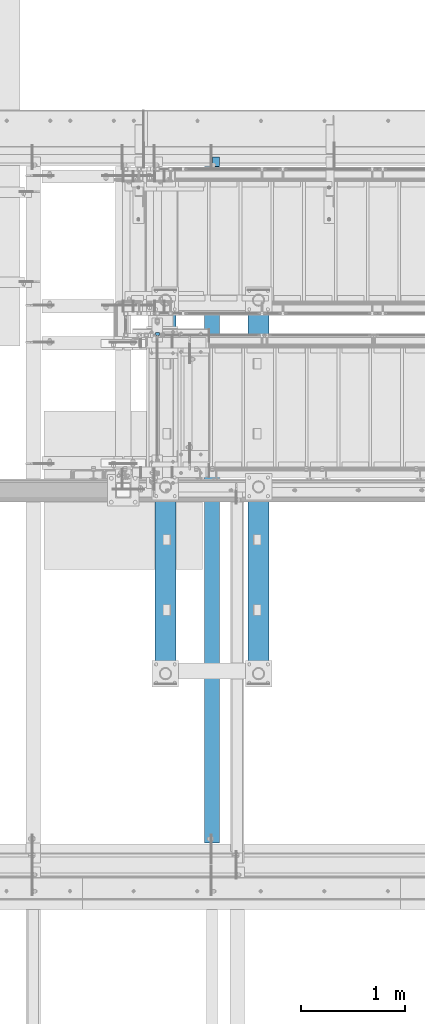
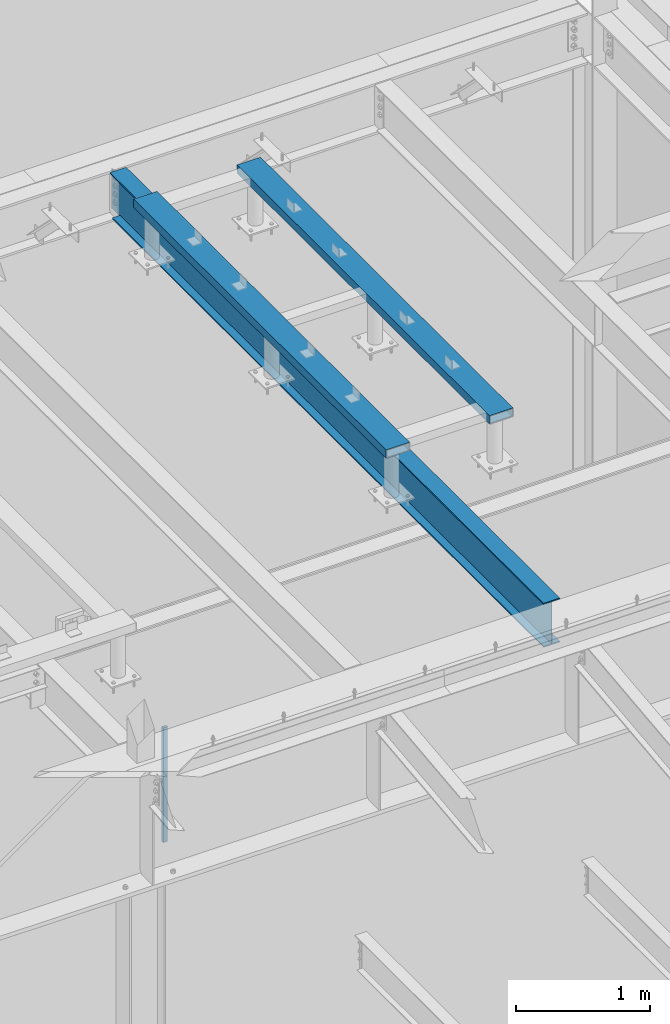
# One storey, part 778 of 1179: 3 beams, 1 member, 3 elements without a shape of their own.
"""IFC2X3 building model written with IfcOpenShell, lengths in millimetres."""

from ifc_helpers import new_model, si_unit, frame, origin_with_axes, place, context, subcontext, project, spatial, faceted_brep, material, type_object, element, aggregate, save


model = new_model("IFC2X3")

# Units and contexts
model_context = context("Model", 3, precision=1e-05, world=origin_with_axes())
body_context = subcontext(model_context, "Body", "Model", "MODEL_VIEW")
ifc_project = project(units=[si_unit("LENGTHUNIT", "METRE", prefix="MILLI"), si_unit("AREAUNIT", "SQUARE_METRE"), si_unit("VOLUMEUNIT", "CUBIC_METRE"), si_unit("MASSUNIT", "GRAM", prefix="KILO"), si_unit("TIMEUNIT", "SECOND"), si_unit("PLANEANGLEUNIT", "RADIAN"), si_unit("SOLIDANGLEUNIT", "STERADIAN"), si_unit("THERMODYNAMICTEMPERATUREUNIT", "DEGREE_CELSIUS"), si_unit("LUMINOUSINTENSITYUNIT", "LUMEN")], contexts=[model_context])

# Site, building, storey
site_placement = place(None, origin_with_axes())
site = spatial("IfcSite", under=ifc_project, at=site_placement, CompositionType="ELEMENT")
building_placement = place(site_placement, origin_with_axes())
building = spatial("IfcBuilding", under=site, at=building_placement, Name="Undefined", CompositionType="ELEMENT")
storey_placement = place(building_placement, origin_with_axes())
storey = spatial("IfcBuildingStorey", under=building, at=storey_placement, Name="Undefined", CompositionType="ELEMENT", Elevation=0.0)

# Assembly, member
assembly_1_placement = place(storey_placement, origin_with_axes())
assembly_1 = element("IfcElementAssembly", 1, at=assembly_1_placement, inside=storey, Name="GUARDRAIL", AssemblyPlace="NOTDEFINED", PredefinedType="RIGID_FRAME")
ifc_material_1 = material(Name="STEEL/A36")
member_type = type_object("IfcMemberType", PredefinedType="NOTDEFINED")
member_placement = place(assembly_1_placement, frame((19605.6249999269, 39484.300002328, 8147.05), z_axis=(-1.0, 0.0, 0.0), x_axis=(0.0, 0.0, 1.0)))
member = element("IfcMember", 2, at=member_placement, type_object=member_type, material=ifc_material_1, Name="POST", context=body_context, shape_type="Brep", body=[
    faceted_brep([(1047.75000059595, -12.6999999999971, 19.0499999999993), (1047.75000059595, -12.6999999999971, -19.0499999999993), (1047.75000059595, 12.6999999999971, -19.0499999999993), (1047.75000059595, 12.6999999999971, 19.0499999999993), (0.0, -12.7000000000007, -19.0500000000029), (0.0, -12.7000000000007, 19.0500000000029), (0.0, 12.7000000000007, 19.0500000000029), (0.0, 12.7000000000007, -19.0500000000029)], [[[0, 1, 2, 3]], [[4, 5, 6, 7]], [[6, 5, 0, 3]], [[7, 6, 3, 2]], [[4, 7, 2, 1]], [[5, 4, 1, 0]]]),
])
aggregate(assembly_1, [member])

# Assembly, beam
assembly_2_placement = place(storey_placement, origin_with_axes())
assembly_2 = element("IfcElementAssembly", 3, at=assembly_2_placement, inside=storey, Name="BEAM", AssemblyPlace="NOTDEFINED", PredefinedType="RIGID_FRAME")
ifc_material_2 = material(Name="STEEL/A992")
beam_type_1 = type_object("IfcBeamType", Name="W16X31", PredefinedType="NOTDEFINED")
beam_1_placement = place(assembly_2_placement, frame((20129.5, 34391.6, 12917.4875), z_axis=(0.0, 0.0, 1.0), x_axis=(0.0, 1.0, 0.0)))
beam_1 = element("IfcBeam", 4, at=beam_1_placement, type_object=beam_type_1, material=ifc_material_2, Name="BEAM", ObjectType="W16X31", context=body_context, shape_type="Brep", body=[
    faceted_brep([(212.724999999999, 69.8499999999985, -190.5), (212.724999999999, 3.17499999999927, -190.5), (6661.94375000001, 3.17499999999927, -190.5), (6661.94375000001, 69.8499999999985, -190.5), (212.724999999999, -3.17499999999927, -190.5), (212.724999999999, -69.8499999999985, -190.5), (6788.94375000001, -69.8499999999985, -190.5), (6788.94375000001, -3.17499999999927, -190.5), (212.724999999999, -69.8499999999985, -201.612499999999), (6788.94375000001, -69.8499999999985, -201.612499999999), (6788.94375000001, 3.17549991607666, -201.612499999999), (6788.94375000001, 3.17499999999927, -190.5), (6788.94375000001, 3.17499999999927, 163.512499999999), (6788.94375000001, -3.17499999999927, 163.512499999999), (6661.94375000001, 3.17549991607666, -201.612499999999), (212.724999999999, 69.8499999999985, -201.612499999999), (6661.94375000001, 69.8499999999985, -201.612499999999), (212.724999999999, -3.17499999999927, 190.5), (212.724999999999, -69.8499999999985, 190.5), (212.724999999999, -69.8499999999985, 201.612499999999), (212.724999999999, 69.8499999999985, 201.612499999999), (212.724999999999, 69.8499999999985, 190.5), (212.724999999999, 3.17499999999927, 190.5), (212.724999999999, 3.17499999999927, 162.664998864024), (212.724999999999, 3.17499999999927, -142.027500567505), (6696.86875000001, 69.8499999999985, 190.5), (6696.86875000001, 3.17499999999927, 190.5), (6696.86875000001, 3.17499999999927, 176.212499809264), (6697.8354799226, 3.17499999999927, 171.352420291218), (6700.58849382307, 3.17499999999927, 167.232243823064), (6704.70867029123, 3.17499999999927, 164.479229922586), (6709.56874980927, 3.17499999999927, 163.512499999999), (6697.8354799226, -3.17499999999927, 171.352420291218), (6696.86875000001, -3.17499999999927, 176.212499809264), (6700.58849382307, -3.17499999999927, 167.232243823064), (6704.70867029123, -3.17499999999927, 164.479229922586), (6709.56874980927, -3.17499999999927, 163.512499999999), (6696.86875000001, -3.17499999999927, 190.5), (6696.86875000001, -69.8499999999985, 190.5), (6696.86875000001, -69.8499999999985, 201.612499999999), (6696.86875000001, 69.8499999999985, 201.612499999999)], [[[0, 1, 2, 3]], [[4, 5, 6, 7]], [[5, 8, 9, 6]], [[7, 6, 9, 10, 11, 12, 13]], [[11, 10, 14, 2]], [[9, 8, 15, 16, 14, 10]], [[2, 14, 16, 3]], [[15, 0, 3, 16]], [[8, 5, 4, 17, 18, 19, 20, 21, 22, 23, 24, 1, 0, 15]], [[22, 21, 25, 26]], [[11, 2, 1, 24, 23, 22, 26, 27, 28, 29, 30, 31, 12]], [[32, 28, 27, 33]], [[34, 29, 28, 32]], [[35, 30, 29, 34]], [[36, 31, 30, 35]], [[13, 12, 31, 36]], [[35, 34, 32, 33, 37, 17, 4, 7, 13, 36]], [[18, 17, 37, 38]], [[19, 18, 38, 39]], [[20, 19, 39, 40]], [[21, 20, 40, 25]], [[39, 38, 37, 33, 27, 26, 25, 40]]]),
])
aggregate(assembly_2, [beam_1])

# Assembly, beams
assembly_3_placement = place(storey_placement, origin_with_axes())
assembly_3 = element("IfcElementAssembly", 5, at=assembly_3_placement, inside=storey, Name="FRAME", AssemblyPlace="NOTDEFINED", PredefinedType="RIGID_FRAME")
ifc_material_3 = material()
beam_type_2 = type_object("IfcBeamType", Name="HSS8X3X1/4", PredefinedType="NOTDEFINED")
beam_2_placement = place(assembly_3_placement, frame((20575.5875, 36126.0225542222, 13722.35), z_axis=(1.0, 0.0, 0.0), x_axis=(0.0, 1.0, 0.0)))
beam_2 = element("IfcBeam", 6, at=beam_2_placement, type_object=beam_type_2, material=ifc_material_3, Name="FRAME", ObjectType="HSS8X3X1/4", context=body_context, shape_type="Brep", body=[
    faceted_brep([(4.76249999999709, 31.75, -95.25), (4.76249999999709, -31.75, -95.25), (3779.8375, -31.75, -95.25), (3779.8375, 31.75, -95.25), (4.76249999999709, -31.75, 95.25), (3779.8375, -31.75, 95.25), (4.76249999999709, 31.75, 95.25), (3779.8375, 31.75, 95.25), (4.76249999999709, 38.1000000000004, -101.599999999999), (4.76249999999709, 38.1000000000004, 101.599999999999), (3779.8375, 38.1000000000004, 101.599999999999), (3779.8375, 38.1000000000004, -101.599999999999), (4.76249999999709, -38.1000000000004, 101.599999999999), (3779.8375, -38.1000000000004, 101.599999999999), (4.76249999999709, -38.1000000000004, -101.599999999999), (3779.8375, -38.1000000000004, -101.599999999999)], [[[0, 1, 2, 3]], [[1, 4, 5, 2]], [[4, 6, 7, 5]], [[6, 0, 3, 7]], [[8, 9, 10, 11]], [[9, 12, 13, 10]], [[12, 14, 15, 13]], [[14, 8, 11, 15]], [[13, 15, 11, 10], [5, 7, 3, 2]], [[14, 12, 9, 8], [6, 4, 1, 0]]]),
])
beam_3_placement = place(assembly_3_placement, frame((19683.4125, 36126.0225542222, 13722.35), z_axis=(1.0, 0.0, 0.0), x_axis=(0.0, 1.0, 0.0)))
beam_3 = element("IfcBeam", 7, at=beam_3_placement, type_object=beam_type_2, material=ifc_material_3, Name="BEAM", ObjectType="HSS8X3X1/4", context=body_context, shape_type="Brep", body=[
    faceted_brep([(4.76249999999709, 31.75, -95.25), (4.76249999999709, -31.75, -95.25), (3779.8375, -31.75, -95.25), (3779.8375, 31.75, -95.25), (4.76249999999709, -31.75, 95.25), (3779.8375, -31.75, 95.25), (4.76249999999709, 31.75, 95.25), (3779.8375, 31.75, 95.25), (4.76249999999709, 38.1000000000004, -101.599999999999), (4.76249999999709, 38.1000000000004, 101.599999999999), (3779.8375, 38.1000000000004, 101.599999999999), (3779.8375, 38.1000000000004, -101.599999999999), (4.76249999999709, -38.1000000000004, 101.599999999999), (3779.8375, -38.1000000000004, 101.599999999999), (4.76249999999709, -38.1000000000004, -101.599999999999), (3779.8375, -38.1000000000004, -101.599999999999)], [[[0, 1, 2, 3]], [[1, 4, 5, 2]], [[4, 6, 7, 5]], [[6, 0, 3, 7]], [[8, 9, 10, 11]], [[9, 12, 13, 10]], [[12, 14, 15, 13]], [[14, 8, 11, 15]], [[13, 15, 11, 10], [5, 7, 3, 2]], [[14, 12, 9, 8], [6, 4, 1, 0]]]),
])
aggregate(assembly_3, [beam_2, beam_3])

save(model, "model.ifc")
